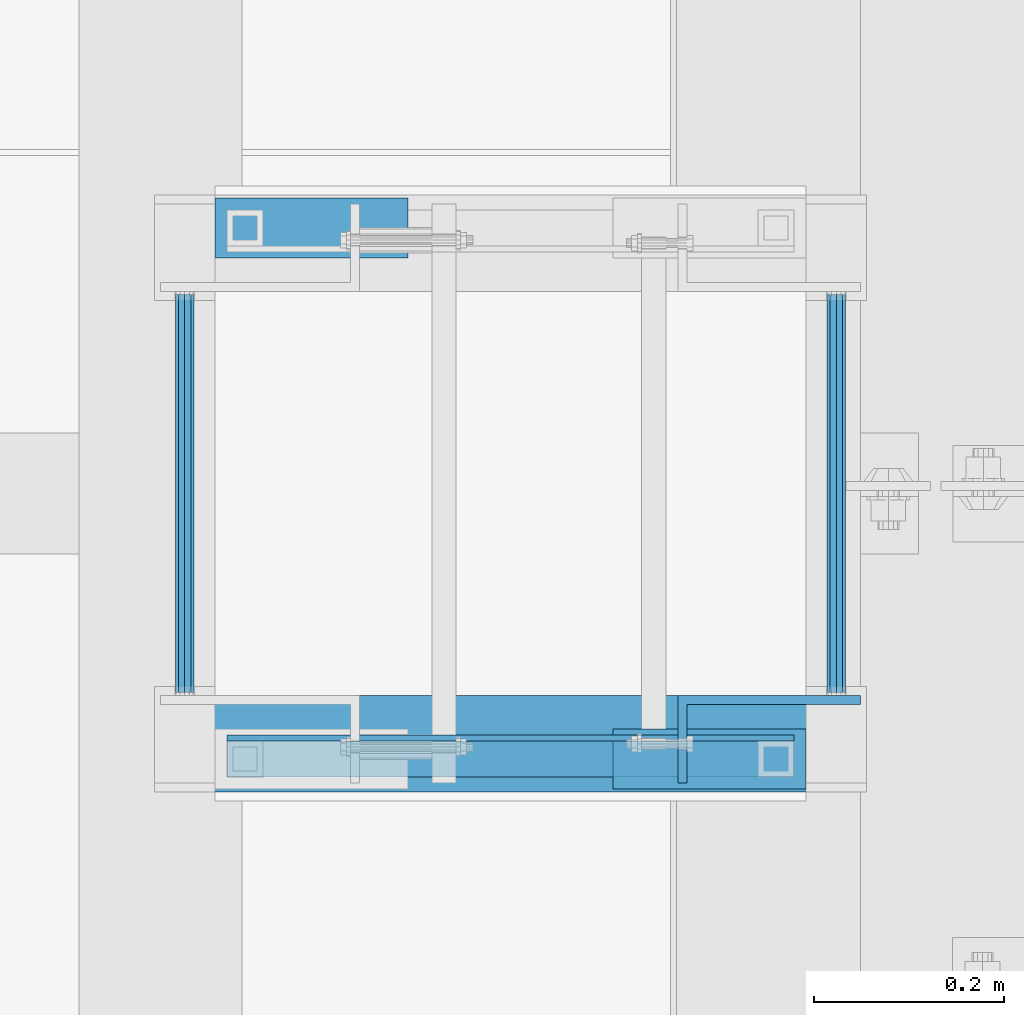
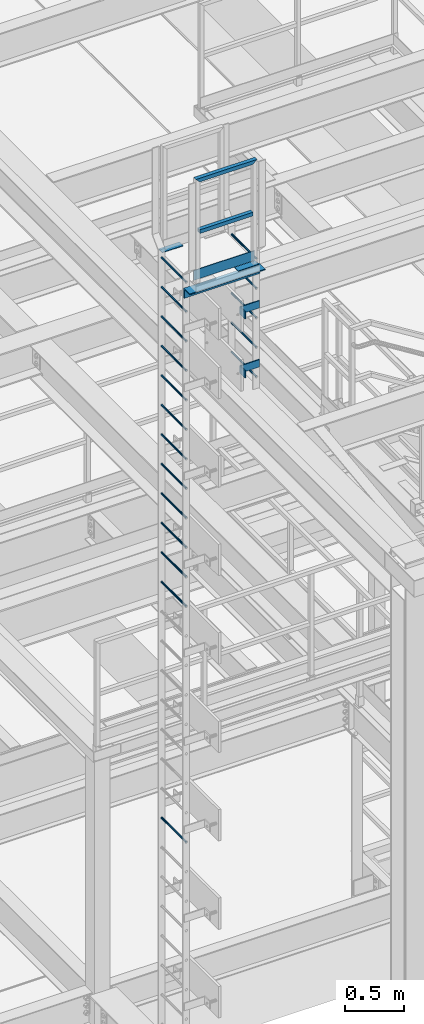
# One storey, part 2057 of 3843: 26 beams, 5 elements without a shape of their own.
"""IFC2X3 building model written with IfcOpenShell, lengths in millimetres."""

from ifc_helpers import new_model, si_unit, frame, origin_with_axes, place, context, subcontext, project, spatial, faceted_brep, material, type_object, element, aggregate, save


model = new_model("IFC2X3")

# Units and contexts
model_context = context("Model", 3, precision=1e-05, world=origin_with_axes())
body_context = subcontext(model_context, "Body", "Model", "MODEL_VIEW")
ifc_project = project(units=[si_unit("LENGTHUNIT", "METRE", prefix="MILLI"), si_unit("AREAUNIT", "SQUARE_METRE"), si_unit("VOLUMEUNIT", "CUBIC_METRE"), si_unit("MASSUNIT", "GRAM", prefix="KILO"), si_unit("TIMEUNIT", "SECOND"), si_unit("PLANEANGLEUNIT", "RADIAN"), si_unit("SOLIDANGLEUNIT", "STERADIAN"), si_unit("THERMODYNAMICTEMPERATUREUNIT", "DEGREE_CELSIUS"), si_unit("LUMINOUSINTENSITYUNIT", "LUMEN")], contexts=[model_context])

# Site, building, storey
site_placement = place(None, origin_with_axes())
site = spatial("IfcSite", under=ifc_project, at=site_placement, CompositionType="ELEMENT")
building_placement = place(site_placement, origin_with_axes())
building = spatial("IfcBuilding", under=site, at=building_placement, Name="Undefined", CompositionType="ELEMENT")
storey_placement = place(building_placement, origin_with_axes())
storey = spatial("IfcBuildingStorey", under=building, at=storey_placement, Name="Undefined", CompositionType="ELEMENT", Elevation=0.0)

# Assembly, beams
assembly_1_placement = place(storey_placement, origin_with_axes())
assembly_1 = element("IfcElementAssembly", 1, at=assembly_1_placement, inside=storey, Name="LADDER", AssemblyPlace="NOTDEFINED", PredefinedType="RIGID_FRAME")
ifc_material_1 = material(Name="STEEL/A36")
beam_type_1 = type_object("IfcBeamType", PredefinedType="NOTDEFINED")
beam_1_placement = place(assembly_1_placement, frame((48917.225012207, 17435.5125, 43021.25), z_axis=(0.0, 0.0, 1.0), x_axis=(-1.0, 0.0, 0.0)))
beam_1 = element("IfcBeam", 2, at=beam_1_placement, type_object=beam_type_1, material=ifc_material_1, Name="BENT_PLATE", context=body_context, shape_type="Brep", body=[
    faceted_brep([(0.0, -4.76250000000073, -38.0999999999985), (0.0, -4.76250000000073, 38.0999999999985), (0.0, 4.76250000000073, 38.0999999999985), (0.0, 4.76250000000073, -38.0999999999985), (182.5625, 4.762500000008, 38.0999999999985), (182.5625, 4.762500000008, -38.0999999999985), (192.087499999994, -4.76249999999345, -38.0999999999985), (192.087499999994, -4.76249999999345, 38.0999999999985), (182.5625, 87.3125000000109, 38.0999999999985), (182.5625, 87.3125000000109, -38.0999999999985), (192.087499999994, 87.3125000000109, 38.0999999999985), (192.087499999994, 87.3125000000109, -38.0999999999985)], [[[0, 1, 2, 3]], [[3, 2, 4, 5]], [[1, 0, 6, 7]], [[5, 4, 8, 9]], [[4, 2, 1, 7, 10, 8]], [[7, 6, 11, 10]], [[6, 0, 3, 5, 9, 11]], [[10, 11, 9, 8]]]),
])
beam_2_placement = place(assembly_1_placement, frame((48917.225012207, 17435.5125, 43630.85), z_axis=(0.0, 0.0, 1.0), x_axis=(-1.0, 0.0, 0.0)))
beam_2 = element("IfcBeam", 3, at=beam_2_placement, type_object=beam_type_1, material=ifc_material_1, Name="BENT_PLATE", context=body_context, shape_type="Brep", body=[
    faceted_brep([(0.0, -4.76250000000073, -38.0999999999985), (0.0, -4.76250000000073, 38.0999999999985), (0.0, 4.76250000000073, 38.0999999999985), (0.0, 4.76250000000073, -38.0999999999985), (182.5625, 4.762500000008, 38.0999999999985), (182.5625, 4.762500000008, -38.0999999999985), (192.087499999994, -4.76249999999345, -38.0999999999985), (192.087499999994, -4.76249999999345, 38.0999999999985), (182.5625, 87.3125000000109, 38.0999999999985), (182.5625, 87.3125000000109, -38.0999999999985), (192.087499999994, 87.3125000000109, 38.0999999999985), (192.087499999994, 87.3125000000109, -38.0999999999985)], [[[0, 1, 2, 3]], [[3, 2, 4, 5]], [[1, 0, 6, 7]], [[5, 4, 8, 9]], [[4, 2, 1, 7, 10, 8]], [[7, 6, 11, 10]], [[6, 0, 3, 5, 9, 11]], [[10, 11, 9, 8]]]),
])

assembly_2_placement = place(storey_placement, origin_with_axes())
assembly_2 = element("IfcElementAssembly", 4, at=assembly_2_placement, inside=storey, Name="RAIL", AssemblyPlace="NOTDEFINED", PredefinedType="RIGID_FRAME")
ifc_material_2 = material()
beam_type_2 = type_object("IfcBeamType", Name="HSS1-1/2X1-1/2X1/4", PredefinedType="NOTDEFINED")
beam_3_placement = place(assembly_2_placement, frame((48269.524987793, 17373.6, 44646.85), z_axis=(0.0, -1.0, 0.0), x_axis=(1.0, 0.0, 0.0)))
beam_3 = element("IfcBeam", 5, at=beam_3_placement, type_object=beam_type_2, material=ifc_material_2, Name="RAIL", ObjectType="HSS1-1/2X1-1/2X1/4", context=body_context, shape_type="Brep", body=[
    faceted_brep([(19.0499992350015, 12.6999993299978, -12.6999993299978), (19.0499992350015, -12.6999993299978, -12.6999993299978), (539.75001373695, -12.6999993299978, -12.6999993300014), (539.75001373695, 12.6999993299978, -12.6999993300014), (19.0499992350015, -12.6999993299978, 12.6999993299978), (539.75001373695, -12.6999993299978, 12.6999993300014), (19.0499992350015, 12.6999993299978, 12.6999993299978), (539.75001373695, 12.6999993299978, 12.6999993300014), (19.0499992350015, 19.0499992350015, -19.0499992350015), (19.0499992350015, 19.0499992350015, 19.0499992350015), (539.75001373695, 19.0499992350015, 19.0499992350015), (539.75001373695, 19.0499992350015, -19.0499992350015), (19.0499992350015, -19.0499992350015, 19.0499992350015), (539.75001373695, -19.0499992350015, 19.0499992350015), (19.0499992350015, -19.0499992350015, -19.0499992350015), (539.75001373695, -19.0499992350015, -19.0499992350015)], [[[0, 1, 2, 3]], [[1, 4, 5, 2]], [[4, 6, 7, 5]], [[6, 0, 3, 7]], [[8, 9, 10, 11]], [[9, 12, 13, 10]], [[12, 14, 15, 13]], [[14, 8, 11, 15]], [[13, 15, 11, 10], [5, 7, 3, 2]], [[14, 12, 9, 8], [6, 4, 1, 0]]]),
])
beam_4_placement = place(assembly_2_placement, frame((48269.524987793, 17373.6, 45180.25), z_axis=(0.0, -1.0, 0.0), x_axis=(1.0, 0.0, 0.0)))
beam_4 = element("IfcBeam", 6, at=beam_4_placement, type_object=beam_type_2, material=ifc_material_2, Name="RAIL", ObjectType="HSS1-1/2X1-1/2X1/4", context=body_context, shape_type="Brep", body=[
    faceted_brep([(-12.6999993309546, 12.6999993299978, -12.6999993299978), (12.6999993300014, -12.6999993299978, -12.6999993300014), (546.099999317878, -12.6999993300014, -12.6999993299978), (571.500012302, 12.6999993299978, -12.6999993300014), (12.6999993290483, -12.6999993299978, 12.6999993299978), (546.100013642004, -12.6999993299978, 12.6999993300014), (-12.6999993300014, 12.6999993299978, 12.6999993300014), (571.500012302, 12.6999993299978, 12.6999993300014), (-19.0499992359546, 19.0499992350015, -19.0499992350015), (-19.0499992350015, 19.0499992350015, 19.0499992350015), (577.850012207004, 19.0499992350015, 19.0499992350015), (577.850012207004, 19.0499992350015, -19.0499992350015), (19.0499992350015, -19.0499992350015, 19.0499992350015), (539.75001373695, -19.0499992350015, 19.0499992350015), (19.0499992350015, -19.0499992350015, -19.0499992350015), (539.75001373695, -19.0499992350015, -19.0499992350015)], [[[0, 1, 2, 3]], [[1, 4, 5, 2]], [[4, 6, 7, 5]], [[6, 0, 3, 7]], [[8, 9, 10, 11]], [[9, 12, 13, 10]], [[12, 14, 15, 13]], [[14, 8, 11, 15]], [[13, 15, 11, 10], [5, 7, 3, 2]], [[14, 12, 9, 8], [6, 4, 1, 0]]]),
])

# Beam
ifc_material_3 = material(Name="STEEL/A572-50")
beam_type_3 = type_object("IfcBeamType", PredefinedType="NOTDEFINED")
beam_5_placement = place(assembly_1_placement, frame((48891.825, 17443.45, 42884.725), z_axis=(-1.0, 0.0, 0.0), x_axis=(0.0, 1.0, 0.0)))
beam_5 = element("IfcBeam", 7, at=beam_5_placement, type_object=beam_type_3, material=ifc_material_3, Name="RUNG", context=body_context, shape_type="Brep", body=[
    faceted_brep([(0.0, -9.52500000000146, 0.0), (0.0, -6.73519209080405, -6.73519209079677), (419.100000000006, -6.73519209080405, -6.73519209079677), (419.100000000006, -9.52500000000146, 0.0), (2.95075507493764e-12, 2.91322521661641e-12, -9.52499961853027), (419.100000000006, 0.0, -9.52499999999418), (0.0, 6.73519209080405, -6.73519209079677), (419.100000000006, 6.73519209080405, -6.73519209079677), (0.0, 9.52500000000146, 0.0), (419.100000000006, 9.52500000000146, 0.0), (0.0, 6.73519209080405, 6.73519209079677), (419.100000000006, 6.73519209080405, 6.73519209079677), (-9.87109982941227e-13, 2.91322521661641e-12, 9.52499961853027), (419.100000000006, 0.0, 9.52499999999418), (0.0, -6.73519209080405, 6.73519209079677), (419.100000000006, -6.73519209080405, 6.73519209079677)], [[[0, 1, 2, 3]], [[1, 4, 5, 2]], [[4, 6, 7, 5]], [[6, 8, 9, 7]], [[8, 10, 11, 9]], [[10, 12, 13, 11]], [[12, 14, 15, 13]], [[14, 0, 3, 15]], [[5, 7, 9, 11, 13, 15, 3, 2]], [[14, 12, 10, 8, 6, 4, 1, 0]]]),
])

beam_6_placement = place(assembly_1_placement, frame((48891.825, 17443.45, 43189.525), z_axis=(-1.0, 0.0, 0.0), x_axis=(0.0, 1.0, 0.0)))
beam_6 = element("IfcBeam", 8, at=beam_6_placement, type_object=beam_type_3, material=ifc_material_3, Name="RUNG", context=body_context, shape_type="Brep", body=[
    faceted_brep([(0.0, -9.52500000000146, 0.0), (0.0, -6.73519209080405, -6.73519209079677), (419.100000000006, -6.73519209080405, -6.73519209079677), (419.100000000006, -9.52500000000146, 0.0), (2.95075507493764e-12, 2.91322521661641e-12, -9.52499961853027), (419.100000000006, 0.0, -9.52499999999418), (0.0, 6.73519209080405, -6.73519209079677), (419.100000000006, 6.73519209080405, -6.73519209079677), (0.0, 9.52500000000146, 0.0), (419.100000000006, 9.52500000000146, 0.0), (0.0, 6.73519209080405, 6.73519209079677), (419.100000000006, 6.73519209080405, 6.73519209079677), (-9.87109982941227e-13, 2.91322521661641e-12, 9.52499961853027), (419.100000000006, 0.0, 9.52499999999418), (0.0, -6.73519209080405, 6.73519209079677), (419.100000000006, -6.73519209080405, 6.73519209079677)], [[[0, 1, 2, 3]], [[1, 4, 5, 2]], [[4, 6, 7, 5]], [[6, 8, 9, 7]], [[8, 10, 11, 9]], [[10, 12, 13, 11]], [[12, 14, 15, 13]], [[14, 0, 3, 15]], [[5, 7, 9, 11, 13, 15, 3, 2]], [[14, 12, 10, 8, 6, 4, 1, 0]]]),
])

beam_7_placement = place(assembly_1_placement, frame((48891.825, 17443.45, 43494.325), z_axis=(-1.0, 0.0, 0.0), x_axis=(0.0, 1.0, 0.0)))
beam_7 = element("IfcBeam", 9, at=beam_7_placement, type_object=beam_type_3, material=ifc_material_3, Name="RUNG", context=body_context, shape_type="Brep", body=[
    faceted_brep([(0.0, -9.52500000000146, 0.0), (0.0, -6.73519209080405, -6.73519209079677), (419.100000000006, -6.73519209080405, -6.73519209079677), (419.100000000006, -9.52500000000146, 0.0), (2.95075507493764e-12, 2.91322521661641e-12, -9.52499961853027), (419.100000000006, 0.0, -9.52499999999418), (0.0, 6.73519209080405, -6.73519209079677), (419.100000000006, 6.73519209080405, -6.73519209079677), (0.0, 9.52500000000146, 0.0), (419.100000000006, 9.52500000000146, 0.0), (0.0, 6.73519209080405, 6.73519209079677), (419.100000000006, 6.73519209080405, 6.73519209079677), (-9.87109982941227e-13, 2.91322521661641e-12, 9.52499961853027), (419.100000000006, 0.0, 9.52499999999418), (0.0, -6.73519209080405, 6.73519209079677), (419.100000000006, -6.73519209080405, 6.73519209079677)], [[[0, 1, 2, 3]], [[1, 4, 5, 2]], [[4, 6, 7, 5]], [[6, 8, 9, 7]], [[8, 10, 11, 9]], [[10, 12, 13, 11]], [[12, 14, 15, 13]], [[14, 0, 3, 15]], [[5, 7, 9, 11, 13, 15, 3, 2]], [[14, 12, 10, 8, 6, 4, 1, 0]]]),
])

beam_8_placement = place(assembly_1_placement, frame((48891.825, 17443.45, 43799.125), z_axis=(-1.0, 0.0, 0.0), x_axis=(0.0, 1.0, 0.0)))
beam_8 = element("IfcBeam", 10, at=beam_8_placement, type_object=beam_type_3, material=ifc_material_3, Name="RUNG", context=body_context, shape_type="Brep", body=[
    faceted_brep([(0.0, -9.52500000000146, 0.0), (0.0, -6.73519209080405, -6.73519209079677), (419.100000000006, -6.73519209080405, -6.73519209079677), (419.100000000006, -9.52500000000146, 0.0), (2.95075507493764e-12, 2.91322521661641e-12, -9.52499961853027), (419.100000000006, 0.0, -9.52499999999418), (0.0, 6.73519209080405, -6.73519209079677), (419.100000000006, 6.73519209080405, -6.73519209079677), (0.0, 9.52500000000146, 0.0), (419.100000000006, 9.52500000000146, 0.0), (0.0, 6.73519209080405, 6.73519209079677), (419.100000000006, 6.73519209080405, 6.73519209079677), (-9.87109982941227e-13, 2.91322521661641e-12, 9.52499961853027), (419.100000000006, 0.0, 9.52499999999418), (0.0, -6.73519209080405, 6.73519209079677), (419.100000000006, -6.73519209080405, 6.73519209079677)], [[[0, 1, 2, 3]], [[1, 4, 5, 2]], [[4, 6, 7, 5]], [[6, 8, 9, 7]], [[8, 10, 11, 9]], [[10, 12, 13, 11]], [[12, 14, 15, 13]], [[14, 0, 3, 15]], [[5, 7, 9, 11, 13, 15, 3, 2]], [[14, 12, 10, 8, 6, 4, 1, 0]]]),
])

beam_9_placement = place(assembly_1_placement, frame((48891.825, 17443.45, 44103.925), z_axis=(-1.0, 0.0, 0.0), x_axis=(0.0, 1.0, 0.0)))
beam_9 = element("IfcBeam", 11, at=beam_9_placement, type_object=beam_type_3, material=ifc_material_3, Name="RUNG", context=body_context, shape_type="Brep", body=[
    faceted_brep([(0.0, -9.52500000000146, 0.0), (0.0, -6.73519209080405, -6.73519209079677), (419.100000000006, -6.73519209080405, -6.73519209079677), (419.100000000006, -9.52500000000146, 0.0), (2.95075507493764e-12, 2.91322521661641e-12, -9.52499961853027), (419.100000000006, 0.0, -9.52499999999418), (0.0, 6.73519209080405, -6.73519209079677), (419.100000000006, 6.73519209080405, -6.73519209079677), (0.0, 9.52500000000146, 0.0), (419.100000000006, 9.52500000000146, 0.0), (0.0, 6.73519209080405, 6.73519209079677), (419.100000000006, 6.73519209080405, 6.73519209079677), (-9.87109982941227e-13, 2.91322521661641e-12, 9.52499961853027), (419.100000000006, 0.0, 9.52499999999418), (0.0, -6.73519209080405, 6.73519209079677), (419.100000000006, -6.73519209080405, 6.73519209079677)], [[[0, 1, 2, 3]], [[1, 4, 5, 2]], [[4, 6, 7, 5]], [[6, 8, 9, 7]], [[8, 10, 11, 9]], [[10, 12, 13, 11]], [[12, 14, 15, 13]], [[14, 0, 3, 15]], [[5, 7, 9, 11, 13, 15, 3, 2]], [[14, 12, 10, 8, 6, 4, 1, 0]]]),
])

aggregate(assembly_1, [beam_5, beam_1, beam_2, beam_6, beam_7, beam_8, beam_9])

# Assembly, beams
assembly_3_placement = place(storey_placement, origin_with_axes())
assembly_3 = element("IfcElementAssembly", 12, at=assembly_3_placement, inside=storey, Name="LADDER", AssemblyPlace="NOTDEFINED", PredefinedType="RIGID_FRAME")
beam_10_placement = place(assembly_3_placement, frame((48206.024987793, 17862.55, 38312.725), z_axis=(1.0, 0.0, 0.0), x_axis=(0.0, -1.0, 0.0)))
beam_10 = element("IfcBeam", 13, at=beam_10_placement, type_object=beam_type_3, material=ifc_material_3, Name="RUNG", context=body_context, shape_type="Brep", body=[
    faceted_brep([(0.0, -9.52500000000146, 0.0), (0.0, -6.73519209080405, -6.73519209079677), (419.100000000006, -6.73519209080405, -6.73519209079677), (419.100000000006, -9.52500000000146, 0.0), (2.95075507493764e-12, 2.91322521661641e-12, -9.52499961853027), (419.100000000006, 0.0, -9.52499999999418), (0.0, 6.73519209080405, -6.73519209079677), (419.100000000006, 6.73519209080405, -6.73519209079677), (0.0, 9.52500000000146, 0.0), (419.100000000006, 9.52500000000146, 0.0), (0.0, 6.73519209080405, 6.73519209079677), (419.100000000006, 6.73519209080405, 6.73519209079677), (-9.87109982941227e-13, 2.91322521661641e-12, 9.52499961853027), (419.100000000006, 0.0, 9.52499999999418), (0.0, -6.73519209080405, 6.73519209079677), (419.100000000006, -6.73519209080405, 6.73519209079677)], [[[0, 1, 2, 3]], [[1, 4, 5, 2]], [[4, 6, 7, 5]], [[6, 8, 9, 7]], [[8, 10, 11, 9]], [[10, 12, 13, 11]], [[12, 14, 15, 13]], [[14, 0, 3, 15]], [[5, 7, 9, 11, 13, 15, 3, 2]], [[14, 12, 10, 8, 6, 4, 1, 0]]]),
])
beam_11_placement = place(assembly_3_placement, frame((48206.024987793, 17862.55, 40751.125), z_axis=(1.0, 0.0, 0.0), x_axis=(0.0, -1.0, 0.0)))
beam_11 = element("IfcBeam", 14, at=beam_11_placement, type_object=beam_type_3, material=ifc_material_3, Name="RUNG", context=body_context, shape_type="Brep", body=[
    faceted_brep([(0.0, -9.52500000000146, 0.0), (0.0, -6.73519209080405, -6.73519209079677), (419.100000000006, -6.73519209080405, -6.73519209079677), (419.100000000006, -9.52500000000146, 0.0), (2.95075507493764e-12, 2.91322521661641e-12, -9.52499961853027), (419.100000000006, 0.0, -9.52499999999418), (0.0, 6.73519209080405, -6.73519209079677), (419.100000000006, 6.73519209080405, -6.73519209079677), (0.0, 9.52500000000146, 0.0), (419.100000000006, 9.52500000000146, 0.0), (0.0, 6.73519209080405, 6.73519209079677), (419.100000000006, 6.73519209080405, 6.73519209079677), (-9.87109982941227e-13, 2.91322521661641e-12, 9.52499961853027), (419.100000000006, 0.0, 9.52499999999418), (0.0, -6.73519209080405, 6.73519209079677), (419.100000000006, -6.73519209080405, 6.73519209079677)], [[[0, 1, 2, 3]], [[1, 4, 5, 2]], [[4, 6, 7, 5]], [[6, 8, 9, 7]], [[8, 10, 11, 9]], [[10, 12, 13, 11]], [[12, 14, 15, 13]], [[14, 0, 3, 15]], [[5, 7, 9, 11, 13, 15, 3, 2]], [[14, 12, 10, 8, 6, 4, 1, 0]]]),
])
beam_12_placement = place(assembly_3_placement, frame((48206.024987793, 17862.55, 41055.925), z_axis=(1.0, 0.0, 0.0), x_axis=(0.0, -1.0, 0.0)))
beam_12 = element("IfcBeam", 15, at=beam_12_placement, type_object=beam_type_3, material=ifc_material_3, Name="RUNG", context=body_context, shape_type="Brep", body=[
    faceted_brep([(0.0, -9.52500000000146, 0.0), (0.0, -6.73519209080405, -6.73519209079677), (419.100000000006, -6.73519209080405, -6.73519209079677), (419.100000000006, -9.52500000000146, 0.0), (2.95075507493764e-12, 2.91322521661641e-12, -9.52499961853027), (419.100000000006, 0.0, -9.52499999999418), (0.0, 6.73519209080405, -6.73519209079677), (419.100000000006, 6.73519209080405, -6.73519209079677), (0.0, 9.52500000000146, 0.0), (419.100000000006, 9.52500000000146, 0.0), (0.0, 6.73519209080405, 6.73519209079677), (419.100000000006, 6.73519209080405, 6.73519209079677), (-9.87109982941227e-13, 2.91322521661641e-12, 9.52499961853027), (419.100000000006, 0.0, 9.52499999999418), (0.0, -6.73519209080405, 6.73519209079677), (419.100000000006, -6.73519209080405, 6.73519209079677)], [[[0, 1, 2, 3]], [[1, 4, 5, 2]], [[4, 6, 7, 5]], [[6, 8, 9, 7]], [[8, 10, 11, 9]], [[10, 12, 13, 11]], [[12, 14, 15, 13]], [[14, 0, 3, 15]], [[5, 7, 9, 11, 13, 15, 3, 2]], [[14, 12, 10, 8, 6, 4, 1, 0]]]),
])
beam_13_placement = place(assembly_3_placement, frame((48206.024987793, 17862.55, 41360.725), z_axis=(1.0, 0.0, 0.0), x_axis=(0.0, -1.0, 0.0)))
beam_13 = element("IfcBeam", 16, at=beam_13_placement, type_object=beam_type_3, material=ifc_material_3, Name="RUNG", context=body_context, shape_type="Brep", body=[
    faceted_brep([(0.0, -9.52500000000146, 0.0), (0.0, -6.73519209080405, -6.73519209079677), (419.100000000006, -6.73519209080405, -6.73519209079677), (419.100000000006, -9.52500000000146, 0.0), (2.95075507493764e-12, 2.91322521661641e-12, -9.52499961853027), (419.100000000006, 0.0, -9.52499999999418), (0.0, 6.73519209080405, -6.73519209079677), (419.100000000006, 6.73519209080405, -6.73519209079677), (0.0, 9.52500000000146, 0.0), (419.100000000006, 9.52500000000146, 0.0), (0.0, 6.73519209080405, 6.73519209079677), (419.100000000006, 6.73519209080405, 6.73519209079677), (-9.87109982941227e-13, 2.91322521661641e-12, 9.52499961853027), (419.100000000006, 0.0, 9.52499999999418), (0.0, -6.73519209080405, 6.73519209079677), (419.100000000006, -6.73519209080405, 6.73519209079677)], [[[0, 1, 2, 3]], [[1, 4, 5, 2]], [[4, 6, 7, 5]], [[6, 8, 9, 7]], [[8, 10, 11, 9]], [[10, 12, 13, 11]], [[12, 14, 15, 13]], [[14, 0, 3, 15]], [[5, 7, 9, 11, 13, 15, 3, 2]], [[14, 12, 10, 8, 6, 4, 1, 0]]]),
])
beam_14_placement = place(assembly_3_placement, frame((48206.024987793, 17862.55, 41665.525), z_axis=(1.0, 0.0, 0.0), x_axis=(0.0, -1.0, 0.0)))
beam_14 = element("IfcBeam", 17, at=beam_14_placement, type_object=beam_type_3, material=ifc_material_3, Name="RUNG", context=body_context, shape_type="Brep", body=[
    faceted_brep([(0.0, -9.52500000000146, 0.0), (0.0, -6.73519209080405, -6.73519209079677), (419.100000000006, -6.73519209080405, -6.73519209079677), (419.100000000006, -9.52500000000146, 0.0), (2.95075507493764e-12, 2.91322521661641e-12, -9.52499961853027), (419.100000000006, 0.0, -9.52499999999418), (0.0, 6.73519209080405, -6.73519209079677), (419.100000000006, 6.73519209080405, -6.73519209079677), (0.0, 9.52500000000146, 0.0), (419.100000000006, 9.52500000000146, 0.0), (0.0, 6.73519209080405, 6.73519209079677), (419.100000000006, 6.73519209080405, 6.73519209079677), (-9.87109982941227e-13, 2.91322521661641e-12, 9.52499961853027), (419.100000000006, 0.0, 9.52499999999418), (0.0, -6.73519209080405, 6.73519209079677), (419.100000000006, -6.73519209080405, 6.73519209079677)], [[[0, 1, 2, 3]], [[1, 4, 5, 2]], [[4, 6, 7, 5]], [[6, 8, 9, 7]], [[8, 10, 11, 9]], [[10, 12, 13, 11]], [[12, 14, 15, 13]], [[14, 0, 3, 15]], [[5, 7, 9, 11, 13, 15, 3, 2]], [[14, 12, 10, 8, 6, 4, 1, 0]]]),
])
beam_15_placement = place(assembly_3_placement, frame((48206.024987793, 17862.55, 41970.325), z_axis=(1.0, 0.0, 0.0), x_axis=(0.0, -1.0, 0.0)))
beam_15 = element("IfcBeam", 18, at=beam_15_placement, type_object=beam_type_3, material=ifc_material_3, Name="RUNG", context=body_context, shape_type="Brep", body=[
    faceted_brep([(0.0, -9.52500000000146, 0.0), (0.0, -6.73519209080405, -6.73519209079677), (419.100000000006, -6.73519209080405, -6.73519209079677), (419.100000000006, -9.52500000000146, 0.0), (2.95075507493764e-12, 2.91322521661641e-12, -9.52499961853027), (419.100000000006, 0.0, -9.52499999999418), (0.0, 6.73519209080405, -6.73519209079677), (419.100000000006, 6.73519209080405, -6.73519209079677), (0.0, 9.52500000000146, 0.0), (419.100000000006, 9.52500000000146, 0.0), (0.0, 6.73519209080405, 6.73519209079677), (419.100000000006, 6.73519209080405, 6.73519209079677), (-9.87109982941227e-13, 2.91322521661641e-12, 9.52499961853027), (419.100000000006, 0.0, 9.52499999999418), (0.0, -6.73519209080405, 6.73519209079677), (419.100000000006, -6.73519209080405, 6.73519209079677)], [[[0, 1, 2, 3]], [[1, 4, 5, 2]], [[4, 6, 7, 5]], [[6, 8, 9, 7]], [[8, 10, 11, 9]], [[10, 12, 13, 11]], [[12, 14, 15, 13]], [[14, 0, 3, 15]], [[5, 7, 9, 11, 13, 15, 3, 2]], [[14, 12, 10, 8, 6, 4, 1, 0]]]),
])
beam_16_placement = place(assembly_3_placement, frame((48206.024987793, 17862.55, 42275.125), z_axis=(1.0, 0.0, 0.0), x_axis=(0.0, -1.0, 0.0)))
beam_16 = element("IfcBeam", 19, at=beam_16_placement, type_object=beam_type_3, material=ifc_material_3, Name="RUNG", context=body_context, shape_type="Brep", body=[
    faceted_brep([(0.0, -9.52500000000146, 0.0), (0.0, -6.73519209080405, -6.73519209079677), (419.100000000006, -6.73519209080405, -6.73519209079677), (419.100000000006, -9.52500000000146, 0.0), (2.95075507493764e-12, 2.91322521661641e-12, -9.52499961853027), (419.100000000006, 0.0, -9.52499999999418), (0.0, 6.73519209080405, -6.73519209079677), (419.100000000006, 6.73519209080405, -6.73519209079677), (0.0, 9.52500000000146, 0.0), (419.100000000006, 9.52500000000146, 0.0), (0.0, 6.73519209080405, 6.73519209079677), (419.100000000006, 6.73519209080405, 6.73519209079677), (-9.87109982941227e-13, 2.91322521661641e-12, 9.52499961853027), (419.100000000006, 0.0, 9.52499999999418), (0.0, -6.73519209080405, 6.73519209079677), (419.100000000006, -6.73519209080405, 6.73519209079677)], [[[0, 1, 2, 3]], [[1, 4, 5, 2]], [[4, 6, 7, 5]], [[6, 8, 9, 7]], [[8, 10, 11, 9]], [[10, 12, 13, 11]], [[12, 14, 15, 13]], [[14, 0, 3, 15]], [[5, 7, 9, 11, 13, 15, 3, 2]], [[14, 12, 10, 8, 6, 4, 1, 0]]]),
])
beam_17_placement = place(assembly_3_placement, frame((48206.024987793, 17862.55, 42579.925), z_axis=(1.0, 0.0, 0.0), x_axis=(0.0, -1.0, 0.0)))
beam_17 = element("IfcBeam", 20, at=beam_17_placement, type_object=beam_type_3, material=ifc_material_3, Name="RUNG", context=body_context, shape_type="Brep", body=[
    faceted_brep([(0.0, -9.52500000000146, 0.0), (0.0, -6.73519209080405, -6.73519209079677), (419.100000000006, -6.73519209080405, -6.73519209079677), (419.100000000006, -9.52500000000146, 0.0), (2.95075507493764e-12, 2.91322521661641e-12, -9.52499961853027), (419.100000000006, 0.0, -9.52499999999418), (0.0, 6.73519209080405, -6.73519209079677), (419.100000000006, 6.73519209080405, -6.73519209079677), (0.0, 9.52500000000146, 0.0), (419.100000000006, 9.52500000000146, 0.0), (0.0, 6.73519209080405, 6.73519209079677), (419.100000000006, 6.73519209080405, 6.73519209079677), (-9.87109982941227e-13, 2.91322521661641e-12, 9.52499961853027), (419.100000000006, 0.0, 9.52499999999418), (0.0, -6.73519209080405, 6.73519209079677), (419.100000000006, -6.73519209080405, 6.73519209079677)], [[[0, 1, 2, 3]], [[1, 4, 5, 2]], [[4, 6, 7, 5]], [[6, 8, 9, 7]], [[8, 10, 11, 9]], [[10, 12, 13, 11]], [[12, 14, 15, 13]], [[14, 0, 3, 15]], [[5, 7, 9, 11, 13, 15, 3, 2]], [[14, 12, 10, 8, 6, 4, 1, 0]]]),
])
beam_18_placement = place(assembly_3_placement, frame((48206.024987793, 17862.55, 42884.725), z_axis=(1.0, 0.0, 0.0), x_axis=(0.0, -1.0, 0.0)))
beam_18 = element("IfcBeam", 21, at=beam_18_placement, type_object=beam_type_3, material=ifc_material_3, Name="RUNG", context=body_context, shape_type="Brep", body=[
    faceted_brep([(0.0, -9.52500000000146, 0.0), (0.0, -6.73519209080405, -6.73519209079677), (419.100000000006, -6.73519209080405, -6.73519209079677), (419.100000000006, -9.52500000000146, 0.0), (2.95075507493764e-12, 2.91322521661641e-12, -9.52499961853027), (419.100000000006, 0.0, -9.52499999999418), (0.0, 6.73519209080405, -6.73519209079677), (419.100000000006, 6.73519209080405, -6.73519209079677), (0.0, 9.52500000000146, 0.0), (419.100000000006, 9.52500000000146, 0.0), (0.0, 6.73519209080405, 6.73519209079677), (419.100000000006, 6.73519209080405, 6.73519209079677), (-9.87109982941227e-13, 2.91322521661641e-12, 9.52499961853027), (419.100000000006, 0.0, 9.52499999999418), (0.0, -6.73519209080405, 6.73519209079677), (419.100000000006, -6.73519209080405, 6.73519209079677)], [[[0, 1, 2, 3]], [[1, 4, 5, 2]], [[4, 6, 7, 5]], [[6, 8, 9, 7]], [[8, 10, 11, 9]], [[10, 12, 13, 11]], [[12, 14, 15, 13]], [[14, 0, 3, 15]], [[5, 7, 9, 11, 13, 15, 3, 2]], [[14, 12, 10, 8, 6, 4, 1, 0]]]),
])
beam_19_placement = place(assembly_3_placement, frame((48206.024987793, 17862.55, 43189.525), z_axis=(1.0, 0.0, 0.0), x_axis=(0.0, -1.0, 0.0)))
beam_19 = element("IfcBeam", 22, at=beam_19_placement, type_object=beam_type_3, material=ifc_material_3, Name="RUNG", context=body_context, shape_type="Brep", body=[
    faceted_brep([(0.0, -9.52500000000146, 0.0), (0.0, -6.73519209080405, -6.73519209079677), (419.100000000006, -6.73519209080405, -6.73519209079677), (419.100000000006, -9.52500000000146, 0.0), (2.95075507493764e-12, 2.91322521661641e-12, -9.52499961853027), (419.100000000006, 0.0, -9.52499999999418), (0.0, 6.73519209080405, -6.73519209079677), (419.100000000006, 6.73519209080405, -6.73519209079677), (0.0, 9.52500000000146, 0.0), (419.100000000006, 9.52500000000146, 0.0), (0.0, 6.73519209080405, 6.73519209079677), (419.100000000006, 6.73519209080405, 6.73519209079677), (-9.87109982941227e-13, 2.91322521661641e-12, 9.52499961853027), (419.100000000006, 0.0, 9.52499999999418), (0.0, -6.73519209080405, 6.73519209079677), (419.100000000006, -6.73519209080405, 6.73519209079677)], [[[0, 1, 2, 3]], [[1, 4, 5, 2]], [[4, 6, 7, 5]], [[6, 8, 9, 7]], [[8, 10, 11, 9]], [[10, 12, 13, 11]], [[12, 14, 15, 13]], [[14, 0, 3, 15]], [[5, 7, 9, 11, 13, 15, 3, 2]], [[14, 12, 10, 8, 6, 4, 1, 0]]]),
])
beam_20_placement = place(assembly_3_placement, frame((48206.024987793, 17862.55, 43494.325), z_axis=(1.0, 0.0, 0.0), x_axis=(0.0, -1.0, 0.0)))
beam_20 = element("IfcBeam", 23, at=beam_20_placement, type_object=beam_type_3, material=ifc_material_3, Name="RUNG", context=body_context, shape_type="Brep", body=[
    faceted_brep([(0.0, -9.52500000000146, 0.0), (0.0, -6.73519209080405, -6.73519209079677), (419.100000000006, -6.73519209080405, -6.73519209079677), (419.100000000006, -9.52500000000146, 0.0), (2.95075507493764e-12, 2.91322521661641e-12, -9.52499961853027), (419.100000000006, 0.0, -9.52499999999418), (0.0, 6.73519209080405, -6.73519209079677), (419.100000000006, 6.73519209080405, -6.73519209079677), (0.0, 9.52500000000146, 0.0), (419.100000000006, 9.52500000000146, 0.0), (0.0, 6.73519209080405, 6.73519209079677), (419.100000000006, 6.73519209080405, 6.73519209079677), (-9.87109982941227e-13, 2.91322521661641e-12, 9.52499961853027), (419.100000000006, 0.0, 9.52499999999418), (0.0, -6.73519209080405, 6.73519209079677), (419.100000000006, -6.73519209080405, 6.73519209079677)], [[[0, 1, 2, 3]], [[1, 4, 5, 2]], [[4, 6, 7, 5]], [[6, 8, 9, 7]], [[8, 10, 11, 9]], [[10, 12, 13, 11]], [[12, 14, 15, 13]], [[14, 0, 3, 15]], [[5, 7, 9, 11, 13, 15, 3, 2]], [[14, 12, 10, 8, 6, 4, 1, 0]]]),
])
beam_21_placement = place(assembly_3_placement, frame((48206.024987793, 17862.55, 43799.125), z_axis=(1.0, 0.0, 0.0), x_axis=(0.0, -1.0, 0.0)))
beam_21 = element("IfcBeam", 24, at=beam_21_placement, type_object=beam_type_3, material=ifc_material_3, Name="RUNG", context=body_context, shape_type="Brep", body=[
    faceted_brep([(0.0, -9.52500000000146, 0.0), (0.0, -6.73519209080405, -6.73519209079677), (419.100000000006, -6.73519209080405, -6.73519209079677), (419.100000000006, -9.52500000000146, 0.0), (2.95075507493764e-12, 2.91322521661641e-12, -9.52499961853027), (419.100000000006, 0.0, -9.52499999999418), (0.0, 6.73519209080405, -6.73519209079677), (419.100000000006, 6.73519209080405, -6.73519209079677), (0.0, 9.52500000000146, 0.0), (419.100000000006, 9.52500000000146, 0.0), (0.0, 6.73519209080405, 6.73519209079677), (419.100000000006, 6.73519209080405, 6.73519209079677), (-9.87109982941227e-13, 2.91322521661641e-12, 9.52499961853027), (419.100000000006, 0.0, 9.52499999999418), (0.0, -6.73519209080405, 6.73519209079677), (419.100000000006, -6.73519209080405, 6.73519209079677)], [[[0, 1, 2, 3]], [[1, 4, 5, 2]], [[4, 6, 7, 5]], [[6, 8, 9, 7]], [[8, 10, 11, 9]], [[10, 12, 13, 11]], [[12, 14, 15, 13]], [[14, 0, 3, 15]], [[5, 7, 9, 11, 13, 15, 3, 2]], [[14, 12, 10, 8, 6, 4, 1, 0]]]),
])
beam_22_placement = place(assembly_3_placement, frame((48206.024987793, 17862.55, 44103.925), z_axis=(1.0, 0.0, 0.0), x_axis=(0.0, -1.0, 0.0)))
beam_22 = element("IfcBeam", 25, at=beam_22_placement, type_object=beam_type_3, material=ifc_material_3, Name="RUNG", context=body_context, shape_type="Brep", body=[
    faceted_brep([(0.0, -9.52500000000146, 0.0), (0.0, -6.73519209080405, -6.73519209079677), (419.100000000006, -6.73519209080405, -6.73519209079677), (419.100000000006, -9.52500000000146, 0.0), (2.95075507493764e-12, 2.91322521661641e-12, -9.52499961853027), (419.100000000006, 0.0, -9.52499999999418), (0.0, 6.73519209080405, -6.73519209079677), (419.100000000006, 6.73519209080405, -6.73519209079677), (0.0, 9.52500000000146, 0.0), (419.100000000006, 9.52500000000146, 0.0), (0.0, 6.73519209080405, 6.73519209079677), (419.100000000006, 6.73519209080405, 6.73519209079677), (-9.87109982941227e-13, 2.91322521661641e-12, 9.52499961853027), (419.100000000006, 0.0, 9.52499999999418), (0.0, -6.73519209080405, 6.73519209079677), (419.100000000006, -6.73519209080405, 6.73519209079677)], [[[0, 1, 2, 3]], [[1, 4, 5, 2]], [[4, 6, 7, 5]], [[6, 8, 9, 7]], [[8, 10, 11, 9]], [[10, 12, 13, 11]], [[12, 14, 15, 13]], [[14, 0, 3, 15]], [[5, 7, 9, 11, 13, 15, 3, 2]], [[14, 12, 10, 8, 6, 4, 1, 0]]]),
])
aggregate(assembly_3, [beam_10, beam_11, beam_12, beam_13, beam_14, beam_15, beam_16, beam_17, beam_18, beam_19, beam_20, beam_21, beam_22])

# Beam
beam_type_4 = type_object("IfcBeamType", PredefinedType="NOTDEFINED")
beam_23_placement = place(assembly_2_placement, frame((48860.0749998093, 17373.6, 44116.625), z_axis=(0.0, -1.0, 0.0), x_axis=(-1.0, 0.0, 0.0)))
beam_23 = element("IfcBeam", 26, at=beam_23_placement, type_object=beam_type_4, material=ifc_material_1, context=body_context, shape_type="Brep", body=[
    faceted_brep([(0.0, 3.17500000000291, -31.75), (0.0, 3.17500000000291, 31.75), (203.199998088516, 3.17500000000291, 31.75), (203.199998088516, 3.17500000000291, -31.75), (0.0, -3.17500000000291, 31.75), (203.199998088516, -3.17500000000291, 31.75), (0.0, -3.17500000000291, -31.75), (203.199998088516, -3.17500000000291, -31.75)], [[[0, 1, 2, 3]], [[1, 4, 5, 2]], [[4, 6, 7, 5]], [[6, 0, 3, 7]], [[5, 7, 3, 2]], [[6, 4, 1, 0]]]),
])

# Assembly, beam
assembly_4_placement = place(storey_placement, origin_with_axes())
assembly_4 = element("IfcElementAssembly", 27, at=assembly_4_placement, inside=storey, Name="RAIL", AssemblyPlace="NOTDEFINED", PredefinedType="RIGID_FRAME")
beam_24_placement = place(assembly_4_placement, frame((48440.9749868372, 17932.4, 44116.625), z_axis=(0.0, -1.0, 0.0), x_axis=(-1.0, 0.0, 0.0)))
beam_24 = element("IfcBeam", 28, at=beam_24_placement, type_object=beam_type_4, material=ifc_material_1, context=body_context, shape_type="Brep", body=[
    faceted_brep([(0.0, 3.17500000000291, -31.75), (0.0, 3.17500000000291, 31.75), (203.199998088516, 3.17500000000291, 31.75), (203.199998088516, 3.17500000000291, -31.75), (0.0, -3.17500000000291, 31.75), (203.199998088516, -3.17500000000291, 31.75), (0.0, -3.17500000000291, -31.75), (203.199998088516, -3.17500000000291, -31.75)], [[[0, 1, 2, 3]], [[1, 4, 5, 2]], [[4, 6, 7, 5]], [[6, 0, 3, 7]], [[5, 7, 3, 2]], [[6, 4, 1, 0]]]),
])
aggregate(assembly_4, [beam_24])

# Beam
beam_type_5 = type_object("IfcBeamType", PredefinedType="NOTDEFINED")
beam_25_placement = place(assembly_2_placement, frame((48250.4749903701, 17395.8249992349, 44183.3), z_axis=(0.0, 0.0, 1.0), x_axis=(1.0, 0.0, 0.0)))
beam_25 = element("IfcBeam", 29, at=beam_25_placement, type_object=beam_type_5, material=ifc_material_1, Name="TOE_PLATE", context=body_context, shape_type="Brep", body=[
    faceted_brep([(0.0, 3.17500000000291, -50.8000000000029), (0.0, 3.17500000000291, 50.8000000000029), (596.900010681646, 3.17499999999927, 50.8000000000029), (596.900010681646, 3.17499999999927, -50.8000000000029), (0.0, -3.17500000000291, 50.8000000000029), (596.900010681646, -3.17499999999927, 50.8000000000029), (0.0, -3.17500000000291, -50.8000000000029), (596.900010681646, -3.17499999999927, -50.8000000000029)], [[[0, 1, 2, 3]], [[1, 4, 5, 2]], [[4, 6, 7, 5]], [[6, 0, 3, 7]], [[5, 7, 3, 2]], [[6, 4, 1, 0]]]),
])

aggregate(assembly_2, [beam_25, beam_23, beam_3, beam_4])

# Assembly, beam
assembly_5_placement = place(storey_placement, origin_with_axes())
assembly_5 = element("IfcElementAssembly", 30, at=assembly_5_placement, inside=storey, Name="ANGLE", AssemblyPlace="NOTDEFINED", PredefinedType="RIGID_FRAME")
beam_type_6 = type_object("IfcBeamType", Name="L4X4X3/8", PredefinedType="NOTDEFINED")
beam_26_placement = place(assembly_5_placement, frame((48920.4, 17389.475, 43999.15), z_axis=(0.0, 0.0, -1.0), x_axis=(-1.0, 0.0, 0.0)))
beam_26 = element("IfcBeam", 31, at=beam_26_placement, type_object=beam_type_6, material=ifc_material_1, Name="ANGLE", ObjectType="L4X4X3/8", context=body_context, shape_type="Brep", body=[
    faceted_brep([(0.0, 50.8000000000029, -50.8000000000029), (0.0, 50.8000000000029, 50.8000000000029), (739.775012207028, 50.7999999999993, 50.8000000000029), (739.775012207028, 50.7999999999993, -50.8000000000029), (0.0, 41.2750000000015, 50.8000000000029), (739.775012207028, 41.2750000000015, 50.8000000000029), (0.0, 41.2749999999942, -41.2750000000015), (739.775012207028, 41.2750000000015, -41.2750000000015), (0.0, -50.8000000000029, -41.2750000000015), (739.775012207028, -50.7999999999993, -41.2750000000015), (0.0, -50.8000000000029, -50.8000000000029), (739.775012207028, -50.7999999999993, -50.8000000000029)], [[[0, 1, 2, 3]], [[1, 4, 5, 2]], [[4, 6, 7, 5]], [[6, 8, 9, 7]], [[8, 10, 11, 9]], [[10, 0, 3, 11]], [[5, 7, 9, 11, 3, 2]], [[10, 8, 6, 4, 1, 0]]]),
])
aggregate(assembly_5, [beam_26])

save(model, "model.ifc")
